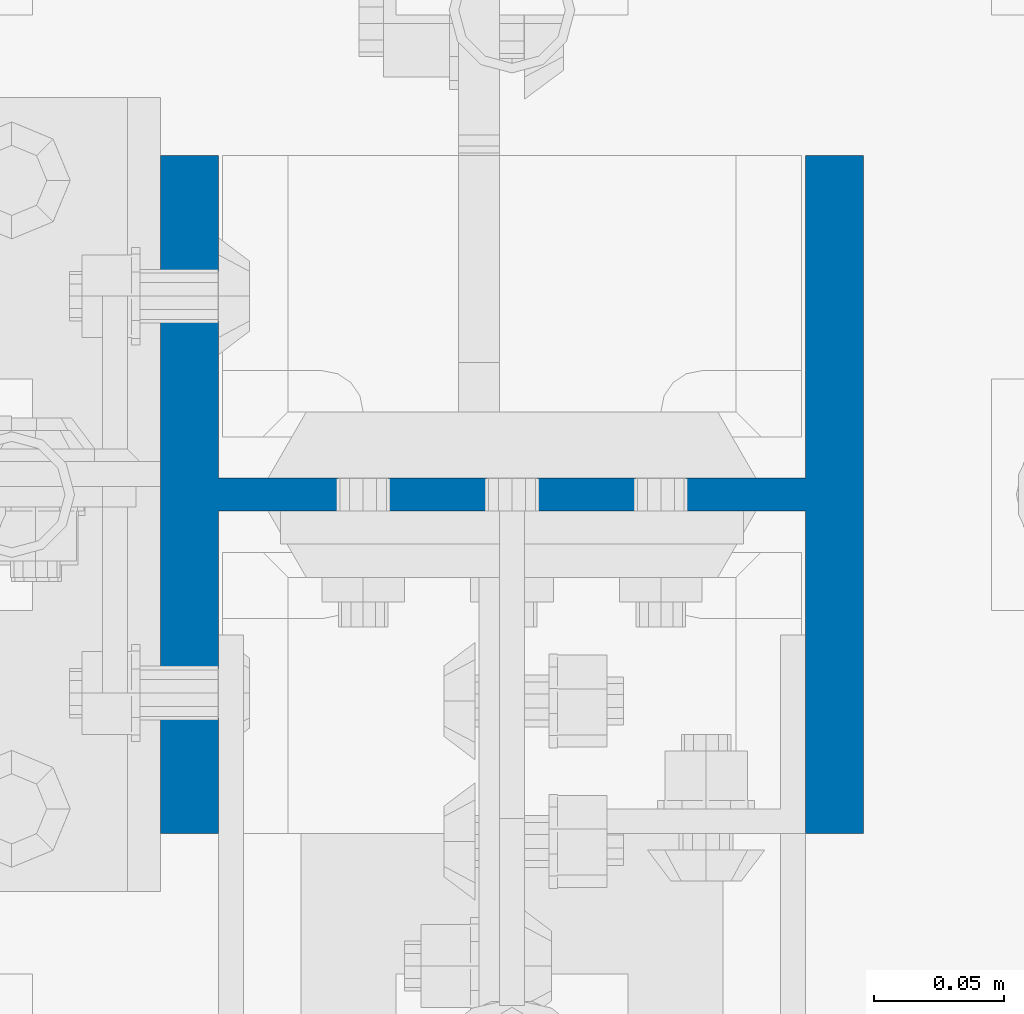
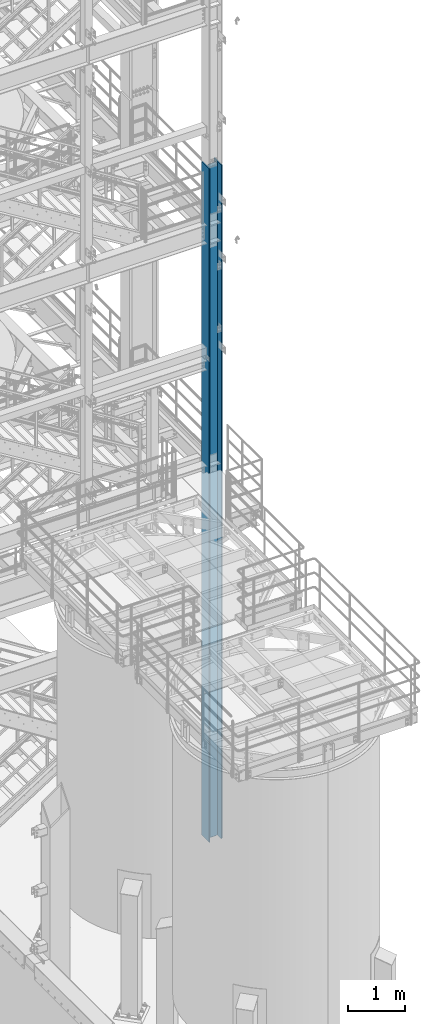
# One storey, part 654 of 1876: 1 column, 1 element without a shape of its own.
"""IFC2X3 building model written with IfcOpenShell, lengths in millimetres."""

import ifcopenshell
import ifcopenshell.guid

model = None  # the IFC model being written
_history = None  # IfcOwnerHistory: only IFC2X3 demands one
_inside = {}  # id of a spatial element -> (the spatial element, [elements in it])
_under = {}  # id of a project, library or spatial element -> (it, [spatial elements below it])
_declared = {}  # id of a project -> (the project, [libraries it declares])
_typed = {}  # id of a type object -> (the type object, [elements of that type])
_made_of = {}  # id of a material, layer set ... -> (it, [elements and type objects made of it])


def new_model(schema):
    """Start an empty IFC model of exactly this schema.

    Asked for "IFC4X3", IfcOpenShell would pick the latest addendum, in which some entities
    have other attributes; the version numbers below select the first issue.
    IFC2X3 requires an IfcOwnerHistory on every rooted entity: one is made here for all.
    """
    global model, _history
    if schema == "IFC4X3":
        model = ifcopenshell.file(schema_version=(4, 3, 0, 0))
    else:
        model = ifcopenshell.file(schema=schema)
    _inside.clear()
    _under.clear()
    _declared.clear()
    _typed.clear()
    _made_of.clear()
    _history = None
    if model.schema == "IFC2X3":
        org = make("IfcOrganization", Name="unknown")
        user = make(
            "IfcPersonAndOrganization",
            ThePerson=make("IfcPerson", FamilyName="unknown"),
            TheOrganization=org,
        )
        app = make(
            "IfcApplication",
            ApplicationDeveloper=org,
            Version="unknown",
            ApplicationFullName="unknown",
            ApplicationIdentifier="unknown",
        )
        _history = make(
            "IfcOwnerHistory",
            OwningUser=user,
            OwningApplication=app,
            ChangeAction="ADDED",
            CreationDate=0,
        )
    return model


def make(cls, **values):
    """One entity of the class cls with the attributes given. An attribute that is None is left unset."""
    return model.create_entity(
        cls, **{name: value for name, value in values.items() if value is not None}
    )


def rooted(cls, **values):
    """An entity with a GlobalId (a new one), such as an element, a storey or a relation."""
    return make(cls, GlobalId=ifcopenshell.guid.new(), OwnerHistory=_history, **values)


def si_unit(unit_type, name, prefix=None):
    """IfcSIUnit, for example si_unit("LENGTHUNIT", "METRE", prefix="MILLI")."""
    return make("IfcSIUnit", UnitType=unit_type, Prefix=prefix, Name=name)


def assignment(units):
    """IfcUnitAssignment: the units of a project."""
    return None if units is None else make("IfcUnitAssignment", Units=units)


def point(xyz):
    """IfcCartesianPoint."""
    return None if xyz is None else make("IfcCartesianPoint", Coordinates=xyz)


def direction(xyz):
    """IfcDirection."""
    return None if xyz is None else make("IfcDirection", DirectionRatios=xyz)


def frame(location, z_axis=None, x_axis=None):
    """IfcAxis2Placement3D, a coordinate frame: its origin and axes. An axis left out is left unset."""
    return make(
        "IfcAxis2Placement3D",
        Location=point(location),
        Axis=direction(z_axis),
        RefDirection=direction(x_axis),
    )


def origin_with_axes():
    """The frame at (0, 0, 0) with the z axis (0, 0, 1) and the x axis (1, 0, 0) written out."""
    return frame((0.0, 0.0, 0.0), z_axis=(0.0, 0.0, 1.0), x_axis=(1.0, 0.0, 0.0))


def place(relative_to, where):
    """IfcLocalPlacement: puts the frame where relative to a parent placement (None: the world)."""
    return make(
        "IfcLocalPlacement", PlacementRelTo=relative_to, RelativePlacement=where
    )


def context(
    kind, dimensions, precision=None, world=None, true_north=None, identifier=None
):
    """IfcGeometricRepresentationContext, for example the 3D "Model" context."""
    return make(
        "IfcGeometricRepresentationContext",
        ContextIdentifier=identifier,
        ContextType=kind,
        CoordinateSpaceDimension=dimensions,
        Precision=precision,
        WorldCoordinateSystem=world,
        TrueNorth=true_north,
    )


def subcontext(parent, identifier, kind, view, scale=None):
    """IfcGeometricRepresentationSubContext, for example "Body" below "Model"."""
    return make(
        "IfcGeometricRepresentationSubContext",
        ContextIdentifier=identifier,
        ContextType=kind,
        ParentContext=parent,
        TargetScale=scale,
        TargetView=view,
    )


def project(units=None, contexts=None):
    """IfcProject with its units and contexts."""
    return rooted(
        "IfcProject",
        Name="project",
        RepresentationContexts=contexts,
        UnitsInContext=assignment(units),
    )


def spatial(cls, under=None, at=None, **own):
    """A site, building, storey or space (cls), placed at a placement, below another one or the project."""
    s = rooted(cls, ObjectPlacement=at, **own)
    if under is not None:
        _under.setdefault(under.id(), (under, []))[1].append(s)
    return s


def faces_of(points, faces, orient=None, outer=None):
    """IfcFace entities. A face is a list of loops; a loop is a list of indices into points, from 0.

    orient and outer hold one flag for each loop. By default every Orientation is true, the
    first loop of a face is its IfcFaceOuterBound and the others are IfcFaceBound.
    """
    made = []
    for i, loops in enumerate(faces):
        bounds = []
        for j, loop in enumerate(loops):
            is_outer = j == 0 if outer is None else outer[i][j]
            bounds.append(
                make(
                    "IfcFaceOuterBound" if is_outer else "IfcFaceBound",
                    Bound=make("IfcPolyLoop", Polygon=[points[k] for k in loop]),
                    Orientation=True if orient is None else orient[i][j],
                )
            )
        made.append(make("IfcFace", Bounds=bounds))
    return made


def faceted_brep(points, faces, orient=None, outer=None, voids=None):
    """IfcFacetedBrep: a solid bounded by flat faces; with voids (closed shells), ...WithVoids."""
    shared = [point(p) for p in points]
    hull = make("IfcClosedShell", CfsFaces=faces_of(shared, faces, orient, outer))
    if voids is None:
        return make("IfcFacetedBrep", Outer=hull)
    return make(
        "IfcFacetedBrepWithVoids",
        Outer=hull,
        Voids=[
            make(cls, CfsFaces=faces_of(shared, fs, o, b)) for cls, fs, o, b in voids
        ],
    )


def shape(context_of_items, identifier, shape_type, items):
    """IfcShapeRepresentation: the items that make up one representation, for example the "Body"."""
    return make(
        "IfcShapeRepresentation",
        ContextOfItems=context_of_items,
        RepresentationIdentifier=identifier,
        RepresentationType=shape_type,
        Items=items,
    )


def material(Name=None, Category=None):
    """IfcMaterial."""
    return make("IfcMaterial", Name=Name, Category=Category)


def made_of(thing, what):
    """Note that an element or type object is made of a material, layer set ...; save() writes the relation."""
    if what is not None:
        _made_of.setdefault(what.id(), (what, []))[1].append(thing)
    return thing


def type_object(cls, material=None, **own):
    """A type object (cls), such as IfcWallType, which elements share."""
    return made_of(rooted(cls, **own), material)


def element(
    cls,
    number,
    at=None,
    inside=None,
    cuts=None,
    type_object=None,
    material=None,
    context=None,
    identifier="Body",
    shape_type=None,
    held_by="IfcProductDefinitionShape",
    body=None,
    shapes=None,
    **own,
):
    """One element of the class cls, such as IfcWall. Its Tag is "e" and its number.

    at: its placement. inside: the storey or other place that contains it. cuts: it is an
    opening in that element (IfcRelVoidsElement). A single representation is given by context,
    identifier, shape_type and body (its items); several are given by shapes. held_by: the class
    of the entity that holds the representations. save() writes the other relations.
    """
    e = rooted(cls, Tag="e%d" % number, ObjectPlacement=at, **own)
    if body is not None:
        shapes = [shape(context, identifier, shape_type, body)]
    if shapes is not None:
        e.Representation = make(held_by, Representations=shapes)
    if inside is not None:
        _inside.setdefault(inside.id(), (inside, []))[1].append(e)
    if cuts is not None:
        rooted(
            "IfcRelVoidsElement", RelatingBuildingElement=cuts, RelatedOpeningElement=e
        )
    if type_object is not None:
        _typed.setdefault(type_object.id(), (type_object, []))[1].append(e)
    return made_of(e, material)


def aggregate(whole, parts):
    """IfcRelAggregates: a whole, such as a stair, and the parts it consists of."""
    return rooted("IfcRelAggregates", RelatingObject=whole, RelatedObjects=parts)


def save(model, path):
    """Write the relations noted so far, then the file.

    IfcRelAggregates (storeys below a building ...), IfcRelContainedInSpatialStructure (elements
    in a storey), IfcRelDefinesByType, IfcRelAssociatesMaterial and IfcRelDeclares: one each for
    every whole, place, type object, material and project.
    """
    for whole, parts in _under.values():
        aggregate(whole, parts)
    for where, things in _inside.values():
        rooted(
            "IfcRelContainedInSpatialStructure",
            RelatedElements=things,
            RelatingStructure=where,
        )
    for kind, things in _typed.values():
        rooted("IfcRelDefinesByType", RelatedObjects=things, RelatingType=kind)
    for what, things in _made_of.values():
        rooted("IfcRelAssociatesMaterial", RelatedObjects=things, RelatingMaterial=what)
    for by, libraries in _declared.values():
        rooted("IfcRelDeclares", RelatingContext=by, RelatedDefinitions=libraries)
    model.write(path)


model = new_model("IFC2X3")

# Units and contexts
model_context = context("Model", 3, precision=1e-05, world=origin_with_axes())
body_context = subcontext(model_context, "Body", "Model", "MODEL_VIEW")
ifc_project = project(units=[si_unit("LENGTHUNIT", "METRE", prefix="MILLI"), si_unit("AREAUNIT", "SQUARE_METRE"), si_unit("VOLUMEUNIT", "CUBIC_METRE"), si_unit("MASSUNIT", "GRAM", prefix="KILO"), si_unit("TIMEUNIT", "SECOND"), si_unit("PLANEANGLEUNIT", "RADIAN"), si_unit("SOLIDANGLEUNIT", "STERADIAN"), si_unit("THERMODYNAMICTEMPERATUREUNIT", "DEGREE_CELSIUS"), si_unit("LUMINOUSINTENSITYUNIT", "LUMEN")], contexts=[model_context])

# Site, building, storey
site_placement = place(None, origin_with_axes())
site = spatial("IfcSite", under=ifc_project, at=site_placement, CompositionType="ELEMENT")
building_placement = place(site_placement, origin_with_axes())
building = spatial("IfcBuilding", under=site, at=building_placement, Name="Undefined", CompositionType="ELEMENT")
storey_placement = place(building_placement, origin_with_axes())
storey = spatial("IfcBuildingStorey", under=building, at=storey_placement, Name="Undefined", CompositionType="ELEMENT", Elevation=0.0)

# Assembly, column
assembly_placement = place(storey_placement, origin_with_axes())
assembly = element("IfcElementAssembly", 1, at=assembly_placement, inside=storey, Name="COLUMN", AssemblyPlace="NOTDEFINED", PredefinedType="RIGID_FRAME")
ifc_material = material(Name="STEEL/A992")
column_type = type_object("IfcColumnType", Name="W10X77", PredefinedType="NOTDEFINED")
column_placement = place(assembly_placement, frame((7620.0, -7112.0, 0.0), z_axis=(-1.0, 0.0, 0.0), x_axis=(0.0, 0.0, 1.0)))
column = element("IfcColumn", 2, at=column_placement, type_object=column_type, material=ifc_material, Name="COLUMN", ObjectType="W10X77", context=body_context, shape_type="Brep", body=[
    faceted_brep([(107.95, -6.35000000000036, 88.5755937151584), (101.600000762938, -7.6293963502394e-07, 87.3125003340556), (95.25, 6.35000000000036, 87.3125003340556), (95.25, 6.35000000000036, -87.3125003814696), (101.600000762939, -7.62940544518642e-07, -87.3125003814696), (107.95, -6.35000000000036, -88.5755937625725), (14528.8, -130.175, 134.9375), (14528.8, 130.175, 134.9375), (117.475, 130.175, 134.9375), (117.475, -130.175, 134.9375), (120.649999999998, -130.175, 112.7125), (14497.05, -130.175, 112.7125), (14528.8, -130.175, 112.7125), (95.25, -130.175, 112.7125), (120.649999999999, -6.35000000000036, 112.712499952586), (14497.05, -6.35000000000036, 112.7125), (14528.8, -6.35000000000036, 112.7125), (95.25, -6.35000000000036, 112.7125), (14528.8, -130.175, -134.9375), (14528.8, -130.175, -112.7125), (14497.05, -130.175, -112.7125), (120.649999999998, -130.175, -112.7125), (95.25, -130.175, -112.7125), (117.475, -130.175, -134.9375), (14528.8, 130.175, -134.9375), (117.475, 130.175, -134.9375), (120.649999999998, 130.175, -112.7125), (14497.05, 130.175, -112.7125), (14528.8, 130.175, -112.7125), (95.25, 130.175, -112.7125), (14528.8, 6.35000000000036, -112.7125), (14528.8, -6.35000000000036, -112.7125), (14497.05, -6.35000000000036, -112.7125), (120.649999999998, -6.35000000000036, -112.7125), (95.25, -6.35000000000036, -112.7125), (108.89011985753, -6.35000000000036, -88.7625952290543), (108.89011985753, 6.35000000000036, -88.7625952290543), (115.070384405063, 6.35000000000036, -92.8921159764066), (115.070384405063, -6.35000000000036, -92.8921159764066), (119.199905152415, 6.35000000000036, -99.0723805239406), (119.199905152415, -6.35000000000036, -99.0723805239406), (120.649999999999, 6.35000000000036, -106.362499618532), (120.649999999999, -6.35000000000036, -106.362499618532), (120.649999999998, 6.35000000000036, -112.7125), (95.25, 6.35000000000036, -112.7125), (14497.05, 6.35000000000036, -112.7125), (14498.6039556076, 6.35000000000036, -102.901210428596), (14498.6039556076, -6.35000000000036, -102.901210428596), (14503.1137104286, 6.35000000000036, -94.050318239714), (14503.1137104286, -6.35000000000036, -94.050318239714), (14510.1378182397, 6.35000000000036, -87.0262104285955), (14510.1378182397, -6.35000000000036, -87.0262104285955), (14518.9887104286, 6.35000000000036, -82.516455607629), (14518.9887104286, -6.35000000000036, -82.516455607629), (14528.8, -6.35000000000036, -80.9625000000001), (14528.8, 6.35000000000036, -80.9625000000001), (14528.8, 6.35000000000036, 80.9625000000001), (14528.8, -6.35000000000036, 80.9625000000001), (14518.9887104286, 6.35000000000036, 82.516455607629), (14518.9887104286, -6.35000000000036, 82.516455607629), (14510.1378182397, 6.35000000000036, 87.0262104285955), (14510.1378182397, -6.35000000000036, 87.0262104285955), (14503.1137104286, 6.35000000000036, 94.050318239714), (14503.1137104286, -6.35000000000036, 94.050318239714), (14498.6039556076, 6.35000000000036, 102.901210428596), (14498.6039556076, -6.35000000000036, 102.901210428596), (14497.05, 6.35000000000036, 112.7125), (14528.8, 6.35000000000036, 112.7125), (14528.8, 130.175, 112.7125), (14497.05, 130.175, 112.7125), (120.649999999998, 130.175, 112.7125), (95.25, 130.175, 112.7125), (95.25, 6.35000000000036, 112.7125), (120.649999999998, 6.35000000000036, 112.7125), (120.649999999999, 6.35000000000036, 106.362499571116), (120.649999999999, -6.35000000000036, 106.362499571116), (119.199905152414, 6.35000000000036, 99.0723804765255), (119.199905152414, -6.35000000000036, 99.0723804765255), (115.070384405062, 6.35000000000036, 92.8921159289921), (115.070384405062, -6.35000000000036, 92.8921159289921), (108.890119857529, 6.35000000000036, 88.7625951816403), (108.890119857529, -6.35000000000036, 88.7625951816403), (101.600000762939, 6.35000000000036, -87.3125003814696), (101.600000762938, 6.35000000000036, 87.3125003340556)], [[[0, 1, 2, 3, 4, 5]], [[6, 7, 8, 9]], [[10, 11, 12, 6, 9, 13]], [[14, 15, 16, 12, 11, 10, 13, 17]], [[18, 19, 20, 21, 22, 23]], [[24, 18, 23, 25]], [[26, 27, 28, 24, 25, 29]], [[19, 18, 24, 28, 30, 31]], [[21, 20, 19, 31, 32, 33, 34, 22]], [[35, 36, 37, 38]], [[38, 37, 39, 40]], [[40, 39, 41, 42]], [[42, 41, 43, 33]], [[33, 43, 44, 34]], [[29, 25, 23, 22, 34, 44]], [[43, 45, 30, 28, 27, 26, 29, 44]], [[31, 30, 45, 32]], [[32, 45, 46, 47]], [[47, 46, 48, 49]], [[49, 48, 50, 51]], [[51, 50, 52, 53]], [[54, 53, 52, 55]], [[56, 57, 54, 55]], [[57, 56, 58, 59]], [[59, 58, 60, 61]], [[61, 60, 62, 63]], [[63, 62, 64, 65]], [[65, 64, 66, 15]], [[16, 15, 66, 67]], [[68, 7, 6, 12, 16, 67]], [[7, 68, 69, 70, 71, 8]], [[13, 9, 8, 71, 72, 17]], [[70, 69, 68, 67, 66, 73, 72, 71]], [[17, 72, 73, 14]], [[14, 73, 74, 75]], [[75, 74, 76, 77]], [[77, 76, 78, 79]], [[79, 78, 80, 81]], [[35, 38, 40, 42, 33, 32, 47, 49, 51, 53, 54, 57, 59, 61, 63, 65, 15, 14, 75, 77, 79, 81, 0, 5]], [[82, 36, 35, 5, 4]], [[82, 4, 3]], [[83, 80, 78, 76, 74, 73, 66, 64, 62, 60, 58, 56, 55, 52, 50, 48, 46, 45, 43, 41, 39, 37, 36, 82, 3, 2]], [[83, 2, 1]], [[81, 80, 83, 1, 0]]]),
])
aggregate(assembly, [column])

save(model, "model.ifc")
